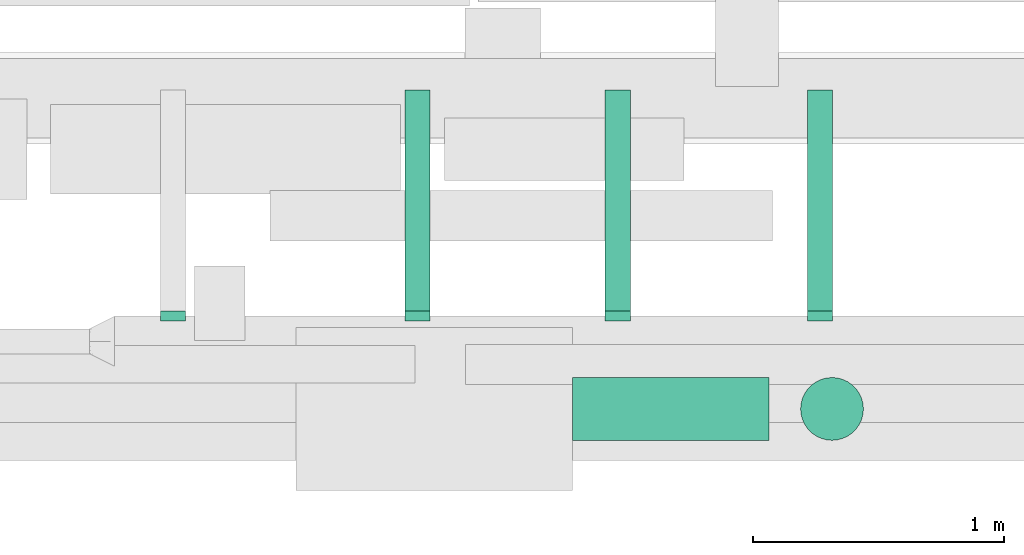
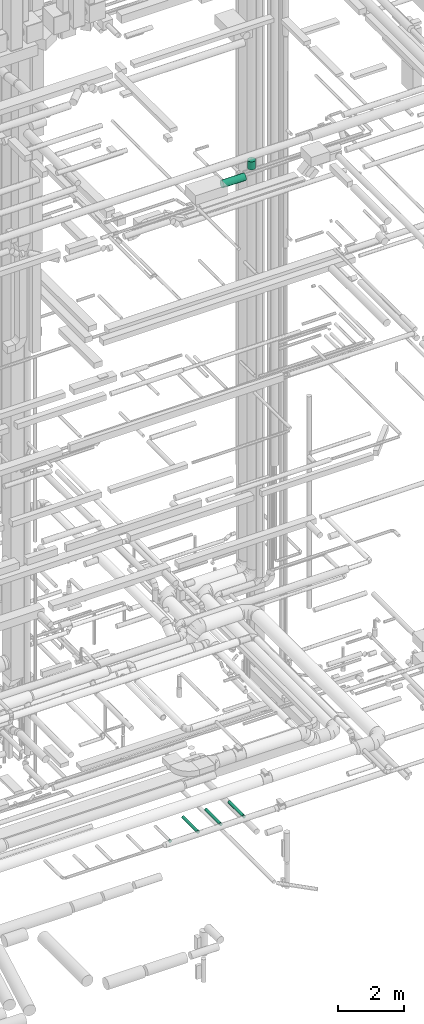
# One storey, part 206 of 337: 5 flow segments, 4 flow fittings.
"""IFC2X3 building model written with IfcOpenShell, lengths in millimetres."""

from ifc_helpers import new_model, entity, si_unit, converted_unit, derived_unit, direction, frame, origin, origin_2d_with_axis, place, context, subcontext, project, spatial, circle, extrude, faceted_brep, source, transform, mapped, material, type_object, type_shapes, element, save


model = new_model("IFC2X3")

# Units and contexts
model_context = context("Model", 3, precision=0.01, world=origin(), true_north=direction((6.12303176911189e-17, 1.0)))
body_context = subcontext(model_context, "Body", "Model", "MODEL_VIEW")
ifc_project = project(units=[si_unit("LENGTHUNIT", "METRE", prefix="MILLI"), si_unit("AREAUNIT", "SQUARE_METRE"), si_unit("VOLUMEUNIT", "CUBIC_METRE"), converted_unit("PLANEANGLEUNIT", "DEGREE", entity("IfcRatioMeasure", 0.0174532925199433), si_unit("PLANEANGLEUNIT", "RADIAN"), dimensions=[0, 0, 0, 0, 0, 0, 0]), si_unit("MASSUNIT", "GRAM", prefix="KILO"), derived_unit("MASSDENSITYUNIT", [(si_unit("MASSUNIT", "GRAM", prefix="KILO"), 1), (si_unit("LENGTHUNIT", "METRE"), -3)]), derived_unit("MOMENTOFINERTIAUNIT", [(si_unit("LENGTHUNIT", "METRE"), 4)]), si_unit("TIMEUNIT", "SECOND"), si_unit("FREQUENCYUNIT", "HERTZ"), si_unit("THERMODYNAMICTEMPERATUREUNIT", "DEGREE_CELSIUS"), derived_unit("THERMALTRANSMITTANCEUNIT", [(si_unit("MASSUNIT", "GRAM", prefix="KILO"), 1), (si_unit("THERMODYNAMICTEMPERATUREUNIT", "KELVIN"), -1), (si_unit("TIMEUNIT", "SECOND"), -3)]), derived_unit("VOLUMETRICFLOWRATEUNIT", [(si_unit("LENGTHUNIT", "METRE"), 3), (si_unit("TIMEUNIT", "SECOND"), -1)]), derived_unit("MASSFLOWRATEUNIT", [(si_unit("MASSUNIT", "GRAM", prefix="KILO"), 1), (si_unit("TIMEUNIT", "SECOND"), -1)]), derived_unit("ROTATIONALFREQUENCYUNIT", [(si_unit("TIMEUNIT", "SECOND"), -1)]), si_unit("ELECTRICCURRENTUNIT", "AMPERE"), si_unit("ELECTRICVOLTAGEUNIT", "VOLT"), si_unit("POWERUNIT", "WATT"), si_unit("FORCEUNIT", "NEWTON", prefix="KILO"), si_unit("ILLUMINANCEUNIT", "LUX"), si_unit("LUMINOUSFLUXUNIT", "LUMEN"), si_unit("LUMINOUSINTENSITYUNIT", "CANDELA"), derived_unit("USERDEFINED", [(si_unit("MASSUNIT", "GRAM", prefix="KILO"), -1), (si_unit("LENGTHUNIT", "METRE"), -2), (si_unit("TIMEUNIT", "SECOND"), 3), (si_unit("LUMINOUSFLUXUNIT", "LUMEN"), 1)]), derived_unit("LINEARVELOCITYUNIT", [(si_unit("LENGTHUNIT", "METRE"), 1), (si_unit("TIMEUNIT", "SECOND"), -1)]), si_unit("PRESSUREUNIT", "PASCAL"), derived_unit("USERDEFINED", [(si_unit("LENGTHUNIT", "METRE"), -2), (si_unit("MASSUNIT", "GRAM", prefix="KILO"), 1), (si_unit("TIMEUNIT", "SECOND"), -2)]), derived_unit("LINEARFORCEUNIT", [(si_unit("MASSUNIT", "GRAM", prefix="KILO"), 1), (si_unit("LENGTHUNIT", "METRE"), 1), (si_unit("TIMEUNIT", "SECOND"), -2), (si_unit("LENGTHUNIT", "METRE"), -1)]), derived_unit("PLANARFORCEUNIT", [(si_unit("MASSUNIT", "GRAM", prefix="KILO"), 1), (si_unit("LENGTHUNIT", "METRE"), 1), (si_unit("TIMEUNIT", "SECOND"), -2), (si_unit("LENGTHUNIT", "METRE"), -2)])], contexts=[model_context])

# Site, building, storey
site_placement = place(None, origin())
site = spatial("IfcSite", under=ifc_project, at=site_placement, CompositionType="ELEMENT")
building_placement = place(site_placement, origin())
building = spatial("IfcBuilding", under=site, at=building_placement, CompositionType="ELEMENT")
storey_placement = place(building_placement, origin())
storey = spatial("IfcBuildingStorey", under=building, at=storey_placement, CompositionType="ELEMENT", Elevation=0.0)

# Flow segments
duct_segment_type = type_object("IfcDuctSegmentType", PredefinedType="NOTDEFINED")
flow_segment_1_placement = place(storey_placement, frame((59994.8, 466.58, 26773.4)))
element("IfcFlowSegment", 1, at=flow_segment_1_placement, inside=storey, type_object=duct_segment_type, context=body_context, shape_type="SweptSolid", body=[
    extrude(circle(Radius=125.0, at=origin_2d_with_axis()), frame((0.0, 126.6, 126.6), z_axis=(1.0, 0.0, 0.0), x_axis=(0.0, -1.0, 0.0)), (0.0, 0.0, 1.0), 782.499999999952),
])
flow_segment_2_placement = place(storey_placement, frame((60900.71, 466.58, 27150.0)))
element("IfcFlowSegment", 2, at=flow_segment_2_placement, inside=storey, type_object=duct_segment_type, context=body_context, shape_type="SweptSolid", body=[
    extrude(circle(Radius=125.0, at=origin_2d_with_axis()), frame((126.6, 126.6, 0.0), z_axis=(0.0, 0.0, 1.0), x_axis=(0.0, 1.0, 0.0)), (0.0, 0.0, 1.0), 295.00000000002),
])
flow_segment_3_placement = place(storey_placement, frame((59326.0, 982.18, 2998.4)))
element("IfcFlowSegment", 3, at=flow_segment_3_placement, inside=storey, type_object=duct_segment_type, context=body_context, shape_type="SweptSolid", body=[
    extrude(circle(Radius=50.0, at=origin_2d_with_axis()), frame((51.6, 0.0, 51.6), z_axis=(0.0, 1.0, 0.0), x_axis=(1.0, 0.0, 0.0)), (0.0, 0.0, 1.0), 880.000000000484),
])
flow_segment_4_placement = place(storey_placement, frame((60123.21, 982.18, 2998.4)))
element("IfcFlowSegment", 4, at=flow_segment_4_placement, inside=storey, type_object=duct_segment_type, context=body_context, shape_type="SweptSolid", body=[
    extrude(circle(Radius=50.0, at=origin_2d_with_axis()), frame((51.6, 0.0, 51.6), z_axis=(0.0, 1.0, 0.0), x_axis=(1.0, 0.0, 0.0)), (0.0, 0.0, 1.0), 880.000000000551),
])
flow_segment_5_placement = place(storey_placement, frame((60927.15, 982.18, 2998.4)))
element("IfcFlowSegment", 5, at=flow_segment_5_placement, inside=storey, type_object=duct_segment_type, context=body_context, shape_type="SweptSolid", body=[
    extrude(circle(Radius=50.0, at=origin_2d_with_axis()), frame((51.6, 0.0, 51.6), z_axis=(0.0, 1.0, 0.0), x_axis=(1.0, 0.0, 0.0)), (0.0, 0.0, 1.0), 880.000000000619),
])

# Flow fittings
ifc_material = material()
duct_fitting_type = type_object("IfcDuctFittingType", PredefinedType="NOTDEFINED", material=ifc_material)
shared_shape = source(origin(), body_context, "Body", "Brep", [
    faceted_brep([(20.0, 0.0, -50.0), (20.0, 12.94, -48.3), (20.0, 25.0, -43.3), (20.0, 35.36, -35.36), (20.0, 43.3, -25.0), (20.0, 48.3, -12.94), (20.0, 50.0, 0.0), (20.0, 48.3, 12.94), (20.0, 43.3, 25.0), (20.0, 35.36, 35.36), (20.0, 25.0, 43.3), (20.0, 12.94, 48.3), (20.0, 0.0, 50.0), (20.0, -12.94, 48.3), (20.0, -25.0, 43.3), (20.0, -35.36, 35.36), (20.0, -43.3, 25.0), (20.0, -48.3, 12.94), (20.0, -50.0, 0.0), (20.0, -48.3, -12.94), (20.0, -43.3, -25.0), (20.0, -35.36, -35.36), (20.0, -25.0, -43.3), (20.0, -12.94, -48.3), (0.0, 0.0, 50.0), (-19.49, 0.0, 50.0), (-19.49, -12.94, 48.3), (0.0, -12.94, 48.3), (-19.49, -25.0, 43.3), (0.0, -25.0, 43.3), (0.0, -35.36, 35.36), (-19.49, -35.36, 35.36), (0.0, -43.3, 25.0), (-19.49, -43.3, 25.0), (-19.49, -48.3, 12.94), (0.0, -48.3, 12.94), (-19.49, -50.0, 0.0), (0.0, -50.0, 0.0), (-19.49, -48.3, -12.94), (0.0, -48.3, -12.94), (-19.49, -43.3, -25.0), (0.0, -43.3, -25.0), (0.0, -35.36, -35.36), (-19.49, -35.36, -35.36), (0.0, -25.0, -43.3), (-19.49, -25.0, -43.3), (-19.49, -12.94, -48.3), (0.0, -12.94, -48.3), (-19.49, 0.0, -50.0), (0.0, 0.0, -50.0), (-19.49, 12.94, -48.3), (0.0, 12.94, -48.3), (-19.49, 25.0, -43.3), (0.0, 25.0, -43.3), (0.0, 35.36, -35.36), (-19.49, 35.36, -35.36), (0.0, 43.3, -25.0), (-19.49, 43.3, -25.0), (-19.49, 48.3, -12.94), (0.0, 48.3, -12.94), (-19.49, 50.0, 0.0), (0.0, 50.0, 0.0), (-19.49, 48.3, 12.94), (0.0, 48.3, 12.94), (-19.49, 43.3, 25.0), (0.0, 43.3, 25.0), (0.0, 35.36, 35.36), (-19.49, 35.36, 35.36), (0.0, 25.0, 43.3), (-19.49, 25.0, 43.3), (-19.49, 12.94, 48.3), (0.0, 12.94, 48.3)], [[[0, 1, 2, 3, 4, 5, 6, 7, 8, 9, 10, 11, 12, 13, 14, 15, 16, 17, 18, 19, 20, 21, 22, 23]], [[13, 12, 24, 25, 26, 27]], [[14, 13, 27, 26, 28, 29]], [[30, 15, 14, 29, 28, 31]], [[17, 16, 32, 33, 34, 35]], [[18, 17, 35, 34, 36, 37]], [[32, 16, 15, 30, 31, 33]], [[19, 18, 37, 36, 38, 39]], [[20, 19, 39, 38, 40, 41]], [[42, 21, 20, 41, 40, 43]], [[23, 22, 44, 45, 46, 47]], [[0, 23, 47, 46, 48, 49]], [[44, 22, 21, 42, 43, 45]], [[1, 0, 49, 48, 50, 51]], [[2, 1, 51, 50, 52, 53]], [[54, 3, 2, 53, 52, 55]], [[5, 4, 56, 57, 58, 59]], [[6, 5, 59, 58, 60, 61]], [[56, 4, 3, 54, 55, 57]], [[7, 6, 61, 60, 62, 63]], [[8, 7, 63, 62, 64, 65]], [[66, 9, 8, 65, 64, 67]], [[11, 10, 68, 69, 70, 71]], [[12, 11, 71, 70, 25, 24]], [[68, 10, 9, 66, 67, 69]], [[46, 45, 43, 40, 38, 36, 34, 33, 31, 28, 26, 25, 70, 69, 67, 64, 62, 60, 58, 57, 55, 52, 50, 48]]]),
])
type_shapes(duct_fitting_type, [shared_shape])
for number, where, z_axis, x_axis in (
    (6, (58405.11, 962.18, 3050.0), (0.0, 0.0, -1.0), (0.0, 1.0, 0.0)),
    (7, (59377.6, 962.18, 3050.0), (0.0, 0.0, -1.0), (0.0, 1.0, 0.0)),
    (8, (60174.8, 962.18, 3050.0), (0.0, 0.0, -1.0), (0.0, 1.0, 0.0)),
    (9, (60978.74, 962.18, 3050.0), (0.0, 0.0, -1.0), (0.0, 1.0, 0.0)),
):
    element("IfcFlowFitting", number, at=place(storey_placement, frame(where, z_axis=z_axis, x_axis=x_axis)), inside=storey, type_object=duct_fitting_type, material=ifc_material, context=body_context, shape_type="MappedRepresentation", body=[
        mapped(shared_shape, transform((0.0, 0.0, 0.0), scale=1.0)),
    ])

save(model, "model.ifc")
